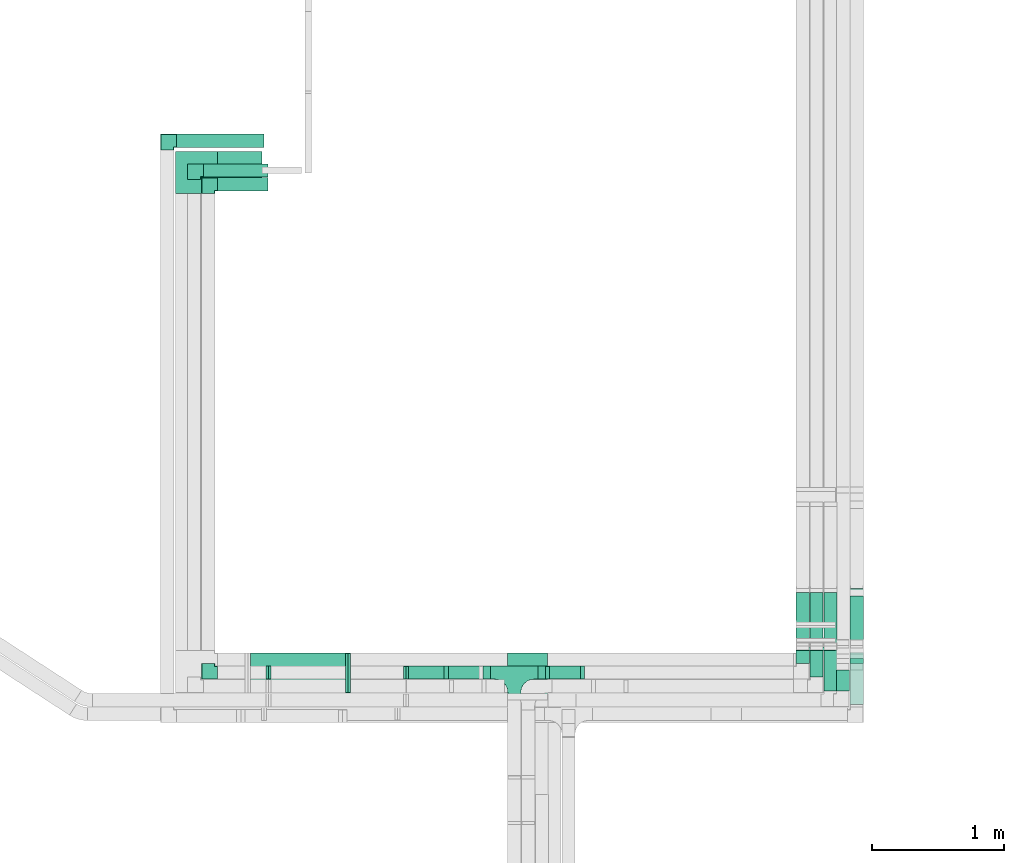
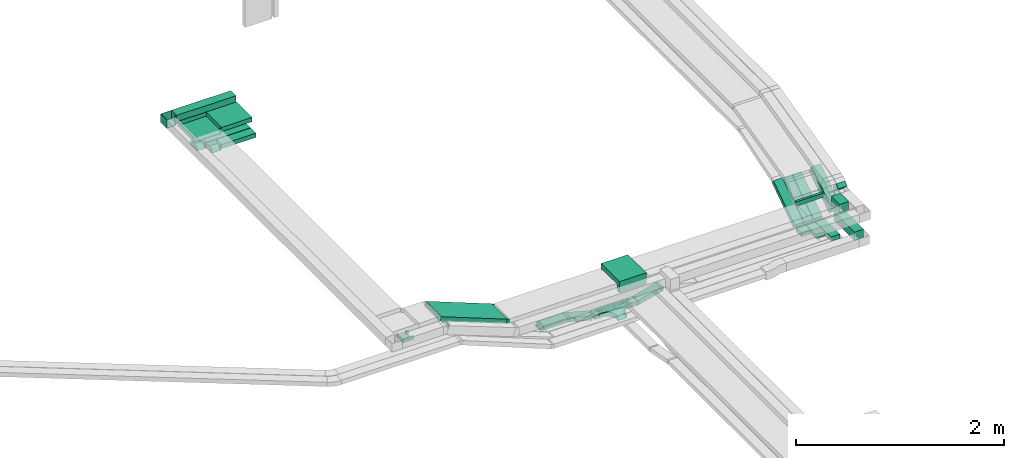
# One storey, part 6 of 14: 21 flow segments, 13 flow fittings.
"""IFC2X3 building model written with IfcOpenShell, lengths in millimetres."""

from ifc_helpers import new_model, entity, si_unit, converted_unit, derived_unit, direction, frame, frame_2d, origin, origin_2d_with_axis, place, context, subcontext, project, spatial, polyline, circle_curve, parameter, trimmed, segment, composite_curve, rectangle, outline, extrude, faceted_brep, source, transform, mapped, material, material_list, type_object, type_shapes, element, save


model = new_model("IFC2X3")

# Units and contexts
model_context = context("Model", 3, precision=0.01, world=origin(), true_north=direction((6.12303176911189e-17, 1.0)))
body_context = subcontext(model_context, "Body", "Model", "MODEL_VIEW")
ifc_project = project(units=[si_unit("LENGTHUNIT", "METRE", prefix="MILLI"), si_unit("AREAUNIT", "SQUARE_METRE"), si_unit("VOLUMEUNIT", "CUBIC_METRE"), converted_unit("PLANEANGLEUNIT", "DEGREE", entity("IfcRatioMeasure", 0.0174532925199433), si_unit("PLANEANGLEUNIT", "RADIAN"), dimensions=[0, 0, 0, 0, 0, 0, 0]), si_unit("MASSUNIT", "GRAM", prefix="KILO"), derived_unit("MASSDENSITYUNIT", [(si_unit("MASSUNIT", "GRAM", prefix="KILO"), 1), (si_unit("LENGTHUNIT", "METRE"), -3)]), derived_unit("MOMENTOFINERTIAUNIT", [(si_unit("LENGTHUNIT", "METRE"), 4)]), si_unit("TIMEUNIT", "SECOND"), si_unit("FREQUENCYUNIT", "HERTZ"), si_unit("THERMODYNAMICTEMPERATUREUNIT", "DEGREE_CELSIUS"), derived_unit("THERMALTRANSMITTANCEUNIT", [(si_unit("MASSUNIT", "GRAM", prefix="KILO"), 1), (si_unit("THERMODYNAMICTEMPERATUREUNIT", "KELVIN"), -1), (si_unit("TIMEUNIT", "SECOND"), -3)]), derived_unit("VOLUMETRICFLOWRATEUNIT", [(si_unit("LENGTHUNIT", "METRE"), 3), (si_unit("TIMEUNIT", "SECOND"), -1)]), derived_unit("MASSFLOWRATEUNIT", [(si_unit("MASSUNIT", "GRAM", prefix="KILO"), 1), (si_unit("TIMEUNIT", "SECOND"), -1)]), derived_unit("ROTATIONALFREQUENCYUNIT", [(si_unit("TIMEUNIT", "SECOND"), -1)]), si_unit("ELECTRICCURRENTUNIT", "AMPERE"), si_unit("ELECTRICVOLTAGEUNIT", "VOLT"), si_unit("POWERUNIT", "WATT"), si_unit("FORCEUNIT", "NEWTON", prefix="KILO"), si_unit("ILLUMINANCEUNIT", "LUX"), si_unit("LUMINOUSFLUXUNIT", "LUMEN"), si_unit("LUMINOUSINTENSITYUNIT", "CANDELA"), derived_unit("USERDEFINED", [(si_unit("MASSUNIT", "GRAM", prefix="KILO"), -1), (si_unit("LENGTHUNIT", "METRE"), -2), (si_unit("TIMEUNIT", "SECOND"), 3), (si_unit("LUMINOUSFLUXUNIT", "LUMEN"), 1)]), derived_unit("LINEARVELOCITYUNIT", [(si_unit("LENGTHUNIT", "METRE"), 1), (si_unit("TIMEUNIT", "SECOND"), -1)]), si_unit("PRESSUREUNIT", "PASCAL"), derived_unit("USERDEFINED", [(si_unit("LENGTHUNIT", "METRE"), -2), (si_unit("MASSUNIT", "GRAM", prefix="KILO"), 1), (si_unit("TIMEUNIT", "SECOND"), -2)]), derived_unit("LINEARFORCEUNIT", [(si_unit("MASSUNIT", "GRAM", prefix="KILO"), 1), (si_unit("LENGTHUNIT", "METRE"), 1), (si_unit("TIMEUNIT", "SECOND"), -2), (si_unit("LENGTHUNIT", "METRE"), -1)]), derived_unit("PLANARFORCEUNIT", [(si_unit("MASSUNIT", "GRAM", prefix="KILO"), 1), (si_unit("LENGTHUNIT", "METRE"), 1), (si_unit("TIMEUNIT", "SECOND"), -2), (si_unit("LENGTHUNIT", "METRE"), -2)])], contexts=[model_context])

# Site, building, storey
site_placement = place(None, origin())
site = spatial("IfcSite", under=ifc_project, at=site_placement, CompositionType="ELEMENT")
building_placement = place(site_placement, origin())
building = spatial("IfcBuilding", under=site, at=building_placement, CompositionType="ELEMENT")
storey_placement = place(building_placement, frame((0.0, 0.0, 19800.0)))
storey = spatial("IfcBuildingStorey", under=building, at=storey_placement, Name="06", CompositionType="ELEMENT", Elevation=19800.0)

# Flow segments
cable_carrier_segment_type = type_object("IfcCableCarrierSegmentType", PredefinedType="CABLETRAYSEGMENT")
flow_segment_1_placement = place(storey_placement, frame((17256.59, 10152.84, 2600.0)))
element("IfcFlowSegment", 1, at=flow_segment_1_placement, inside=storey, type_object=cable_carrier_segment_type, context=body_context, shape_type="SweptSolid", body=[
    extrude(rectangle(XDim=269.725224847366, YDim=99.9999999999989, at=origin_2d_with_axis()), frame((134.86, 50.0, 0.0)), (0.0, 0.0, 1.0), 49.9999999999973),
])
flow_segment_2_placement = place(storey_placement, frame((20600.22, 9960.23, 2600.0)))
element("IfcFlowSegment", 2, at=flow_segment_2_placement, inside=storey, type_object=cable_carrier_segment_type, context=body_context, shape_type="SweptSolid", body=[
    extrude(rectangle(XDim=396.146721820888, YDim=100.000000000003, at=origin_2d_with_axis()), frame((50.0, 198.07, 0.0), z_axis=(0.0, 0.0, 1.0), x_axis=(0.0, 1.0, 0.0)), (0.0, 0.0, 1.0), 99.9999999999989),
])
flow_segment_3_placement = place(storey_placement, frame((20600.22, 10396.27, 2629.3)))
element("IfcFlowSegment", 3, at=flow_segment_3_placement, inside=storey, type_object=cable_carrier_segment_type, context=body_context, shape_type="SweptSolid", body=[
    extrude(rectangle(XDim=100.000000000001, YDim=467.368346274404, at=frame_2d((0.0, 0.0), x_axis=(0.0, 1.0))), frame((0.0, 221.69, 172.13), z_axis=(1.0, 0.0, 0.0), x_axis=(0.0, 0.829037572555048, 0.559192903470738)), (0.0, 0.0, 1.0), 100.000000000003),
])
flow_segment_4_placement = place(storey_placement, frame((20400.22, 10064.24, 2600.0)))
element("IfcFlowSegment", 4, at=flow_segment_4_placement, inside=storey, type_object=cable_carrier_segment_type, context=body_context, shape_type="SweptSolid", body=[
    extrude(rectangle(XDim=311.24039895918, YDim=100.000000000003, at=origin_2d_with_axis()), frame((50.0, 155.62, 0.0), z_axis=(0.0, 0.0, 1.0), x_axis=(0.0, -1.0, 0.0)), (0.0, 0.0, 1.0), 50.0000000000016),
])
flow_segment_5_placement = place(storey_placement, frame((20400.22, 10401.4, 2616.47)))
element("IfcFlowSegment", 5, at=flow_segment_5_placement, inside=storey, type_object=cable_carrier_segment_type, context=body_context, shape_type="SweptSolid", body=[
    extrude(rectangle(XDim=49.9999999999964, YDim=493.947448455053, at=frame_2d((0.0, 0.0), x_axis=(0.0, 1.0))), frame((0.0, 218.73, 158.83), z_axis=(1.0, 0.0, 0.0), x_axis=(0.0, 0.829037572555015, 0.559192903470787)), (0.0, 0.0, 1.0), 100.000000000003),
])
flow_segment_6_placement = place(storey_placement, frame((20295.22, 10401.4, 2616.47)))
element("IfcFlowSegment", 6, at=flow_segment_6_placement, inside=storey, type_object=cable_carrier_segment_type, context=body_context, shape_type="SweptSolid", body=[
    extrude(rectangle(XDim=49.9999999999977, YDim=493.947448455056, at=frame_2d((0.0, 0.0), x_axis=(0.0, 1.0))), frame((0.0, 218.73, 158.83), z_axis=(1.0, 0.0, 0.0), x_axis=(0.0, 0.829037572555018, 0.559192903470783)), (0.0, 0.0, 1.0), 100.000000000003),
])
flow_segment_7_placement = place(storey_placement, frame((20190.22, 10401.4, 2616.47)))
element("IfcFlowSegment", 7, at=flow_segment_7_placement, inside=storey, type_object=cable_carrier_segment_type, context=body_context, shape_type="SweptSolid", body=[
    extrude(rectangle(XDim=49.9999999999964, YDim=493.947448455053, at=frame_2d((0.0, 0.0), x_axis=(0.0, 1.0))), frame((0.0, 218.73, 158.83), z_axis=(1.0, 0.0, 0.0), x_axis=(0.0, 0.829037572555015, 0.559192903470787)), (0.0, 0.0, 1.0), 100.000000000003),
])
flow_segment_8_placement = place(storey_placement, frame((20295.22, 10169.82, 2600.0)))
element("IfcFlowSegment", 8, at=flow_segment_8_placement, inside=storey, type_object=cable_carrier_segment_type, context=body_context, shape_type="SweptSolid", body=[
    extrude(rectangle(XDim=205.655049876662, YDim=100.000000000003, at=origin_2d_with_axis()), frame((50.0, 102.83, 0.0), z_axis=(0.0, 0.0, 1.0), x_axis=(0.0, -1.0, 0.0)), (0.0, 0.0, 1.0), 49.999999999993),
])
flow_segment_9_placement = place(storey_placement, frame((20190.22, 10272.84, 2600.0)))
element("IfcFlowSegment", 9, at=flow_segment_9_placement, inside=storey, type_object=cable_carrier_segment_type, context=body_context, shape_type="SweptSolid", body=[
    extrude(rectangle(XDim=102.633638913558, YDim=100.000000000003, at=origin_2d_with_axis()), frame((50.0, 51.32, 0.0), z_axis=(0.0, 0.0, 1.0), x_axis=(0.0, 1.0, 0.0)), (0.0, 0.0, 1.0), 49.9999999999973),
])
flow_segment_10_placement = place(storey_placement, frame((20600.22, 10271.78, 2948.93)))
element("IfcFlowSegment", 10, at=flow_segment_10_placement, inside=storey, type_object=cable_carrier_segment_type, context=body_context, shape_type="SweptSolid", body=[
    extrude(rectangle(XDim=53.3220562203544, YDim=99.999999999999, at=origin_2d_with_axis()), frame((0.0, 54.21, 54.21), z_axis=(1.0, 0.0, 0.0), x_axis=(0.0, -0.707106781186487, -0.707106781186608)), (0.0, 0.0, 1.0), 100.000000000003),
])
flow_segment_11_placement = place(storey_placement, frame((20495.22, 10064.24, 2900.0)))
element("IfcFlowSegment", 11, at=flow_segment_11_placement, inside=storey, type_object=cable_carrier_segment_type, context=body_context, shape_type="SweptSolid", body=[
    extrude(rectangle(XDim=160.114335996502, YDim=100.000000000003, at=origin_2d_with_axis()), frame((50.0, 80.06, 0.0), z_axis=(0.0, 0.0, 1.0), x_axis=(0.0, 1.0, 0.0)), (0.0, 0.0, 1.0), 100.000000000003),
])
flow_segment_12_placement = place(storey_placement, frame((20190.22, 10370.13, 2900.0)))
element("IfcFlowSegment", 12, at=flow_segment_12_placement, inside=storey, type_object=cable_carrier_segment_type, context=body_context, shape_type="SweptSolid", body=[
    extrude(rectangle(XDim=28.3940759827228, YDim=300.000000000001, at=origin_2d_with_axis()), frame((150.0, 14.2, 0.0), z_axis=(0.0, 0.0, 1.0), x_axis=(0.0, -1.0, 0.0)), (0.0, 0.0, 1.0), 49.999999999993),
])
flow_segment_13_placement = place(storey_placement, frame((18310.63, 10152.84, 2531.55)))
element("IfcFlowSegment", 13, at=flow_segment_13_placement, inside=storey, type_object=cable_carrier_segment_type, context=body_context, shape_type="SweptSolid", body=[
    extrude(rectangle(XDim=49.9999999999963, YDim=99.9999999999989, at=origin_2d_with_axis()), frame((6.47, 50.0, 24.15), z_axis=(0.965925826289085, 0.0, 0.258819045102459), x_axis=(-0.258819045102459, 0.0, 0.965925826289085)), (0.0, 0.0, 1.0), 255.518225265326),
])
flow_segment_14_placement = place(storey_placement, frame((18237.14, 10152.84, 2527.53)))
element("IfcFlowSegment", 14, at=flow_segment_14_placement, inside=storey, type_object=cable_carrier_segment_type, context=body_context, shape_type="SweptSolid", body=[
    extrude(rectangle(XDim=55.8887887634152, YDim=99.9999999999989, at=origin_2d_with_axis()), frame((27.94, 50.0, 0.0), z_axis=(0.0, 0.0, 1.0), x_axis=(-1.0, 0.0, 0.0)), (0.0, 0.0, 1.0), 49.9999999999973),
])
flow_segment_15_placement = place(storey_placement, frame((17543.91, 10152.84, 2531.55)))
element("IfcFlowSegment", 15, at=flow_segment_15_placement, inside=storey, type_object=cable_carrier_segment_type, context=body_context, shape_type="SweptSolid", body=[
    extrude(rectangle(XDim=49.9999999999963, YDim=99.9999999999989, at=frame_2d((0.0, 0.0), x_axis=(0.0, 1.0))), frame((6.47, 50.0, 90.28), z_axis=(0.965925826289085, 0.0, -0.258819045102459), x_axis=(0.0, 1.0, 0.0)), (0.0, 0.0, 1.0), 255.518225265326),
])
flow_segment_16_placement = place(storey_placement, frame((17821.26, 10152.84, 2527.53)))
element("IfcFlowSegment", 16, at=flow_segment_16_placement, inside=storey, type_object=cable_carrier_segment_type, context=body_context, shape_type="SweptSolid", body=[
    extrude(rectangle(XDim=55.8887887635105, YDim=99.9999999999989, at=origin_2d_with_axis()), frame((27.94, 50.0, 0.0)), (0.0, 0.0, 1.0), 49.9999999999973),
])
flow_segment_17_placement = place(storey_placement, frame((16040.11, 10050.13, 2907.31)))
element("IfcFlowSegment", 17, at=flow_segment_17_placement, inside=storey, type_object=cable_carrier_segment_type, context=body_context, shape_type="SweptSolid", body=[
    extrude(rectangle(XDim=49.9999999999997, YDim=300.000000000001, at=frame_2d((0.0, 0.0), x_axis=(0.0, 1.0))), frame((9.1, 150.0, 312.1), z_axis=(0.931412677772554, 0.0, -0.36396486600297), x_axis=(0.0, 1.0, 0.0)), (0.0, 0.0, 1.0), 793.526444095363),
])
flow_segment_18_placement = place(storey_placement, frame((15810.0, 13850.13, 3200.0)))
element("IfcFlowSegment", 18, at=flow_segment_18_placement, inside=storey, type_object=cable_carrier_segment_type, context=body_context, shape_type="SweptSolid", body=[
    extrude(rectangle(XDim=337.305497573283, YDim=300.000000000001, at=origin_2d_with_axis()), frame((168.65, 150.0, 0.0)), (0.0, 0.0, 1.0), 49.9999999999973),
])
flow_segment_19_placement = place(storey_placement, frame((15498.62, 14180.23, 3200.0)))
element("IfcFlowSegment", 19, at=flow_segment_19_placement, inside=storey, type_object=cable_carrier_segment_type, context=body_context, shape_type="SweptSolid", body=[
    extrude(rectangle(XDim=661.375838147948, YDim=99.9999999999989, at=origin_2d_with_axis()), frame((330.69, 50.0, 0.0)), (0.0, 0.0, 1.0), 100.000000000003),
])
flow_segment_20_placement = place(storey_placement, frame((15810.0, 13850.13, 3000.0)))
element("IfcFlowSegment", 20, at=flow_segment_20_placement, inside=storey, type_object=cable_carrier_segment_type, context=body_context, shape_type="SweptSolid", body=[
    extrude(rectangle(XDim=381.506330110017, YDim=99.9999999999989, at=origin_2d_with_axis()), frame((190.75, 50.0, 0.0)), (0.0, 0.0, 1.0), 49.9999999999973),
])
flow_segment_21_placement = place(storey_placement, frame((15701.77, 13954.94, 3000.0)))
element("IfcFlowSegment", 21, at=flow_segment_21_placement, inside=storey, type_object=cable_carrier_segment_type, context=body_context, shape_type="SweptSolid", body=[
    extrude(rectangle(XDim=489.733815594426, YDim=99.9999999999989, at=origin_2d_with_axis()), frame((244.87, 50.0, 0.0)), (0.0, 0.0, 1.0), 49.9999999999973),
])

# Flow fittings
ifc_material = material()
cable_carrier_fitting_type_1 = type_object("IfcCableCarrierFittingType", PredefinedType="NOTDEFINED", material=ifc_material)
shared_shape_1 = source(origin(), body_context, "Body", "Brep", [
    faceted_brep([(-53.41, -124.12, 25.0), (-50.0, -150.0, 25.0), (-50.0, -180.0, 25.0), (-49.2, -180.0, 25.0), (-49.2, -150.0, 25.0), (-52.63, -123.91, 25.0), (-62.7, -99.6, 25.0), (-78.72, -78.72, 25.0), (-99.6, -62.7, 25.0), (-123.91, -52.63, 25.0), (-150.0, -49.2, 25.0), (-180.0, -49.2, 25.0), (-180.0, -50.0, 25.0), (-150.0, -50.0, 25.0), (-124.12, -53.41, 25.0), (-100.0, -63.4, 25.0), (-79.29, -79.29, 25.0), (-63.4, -100.0, 25.0), (180.0, -50.0, 25.0), (180.0, -49.2, 25.0), (150.0, -49.2, 25.0), (123.91, -52.63, 25.0), (99.6, -62.7, 25.0), (78.72, -78.72, 25.0), (62.7, -99.6, 25.0), (52.63, -123.91, 25.0), (49.2, -150.0, 25.0), (49.2, -180.0, 25.0), (50.0, -180.0, 25.0), (50.0, -150.0, 25.0), (53.41, -124.12, 25.0), (63.4, -100.0, 25.0), (79.29, -79.29, 25.0), (100.0, -63.4, 25.0), (124.12, -53.41, 25.0), (150.0, -50.0, 25.0), (180.0, 49.2, 25.0), (180.0, 50.0, 25.0), (-180.0, 50.0, 25.0), (-180.0, 49.2, 25.0), (-180.0, -50.0, -25.0), (-180.0, 50.0, -25.0), (180.0, 50.0, -25.0), (180.0, -50.0, -25.0), (150.0, -50.0, -25.0), (124.12, -53.41, -25.0), (100.0, -63.4, -25.0), (79.29, -79.29, -25.0), (63.4, -100.0, -25.0), (53.41, -124.12, -25.0), (50.0, -150.0, -25.0), (50.0, -180.0, -25.0), (-50.0, -180.0, -25.0), (-50.0, -150.0, -25.0), (-53.41, -124.12, -25.0), (-63.4, -100.0, -25.0), (-79.29, -79.29, -25.0), (-100.0, -63.4, -25.0), (-124.12, -53.41, -25.0), (-150.0, -50.0, -25.0), (-50.0, -150.0, -24.2), (49.2, -180.0, -24.2), (-49.2, -180.0, -24.2), (-49.2, -150.0, -24.2), (-150.0, -49.2, -24.2), (-180.0, -49.2, -24.2), (180.0, -49.2, -24.2), (150.0, -49.2, -24.2), (-180.0, 49.2, -24.2), (-150.0, -50.0, -24.2), (150.0, -50.0, -24.2), (180.0, 49.2, -24.2), (49.2, -150.0, -24.2), (50.0, -150.0, -24.2), (-123.91, -52.63, -24.2), (-99.6, -62.7, -24.2), (-78.72, -78.72, -24.2), (-62.7, -99.6, -24.2), (-52.63, -123.91, -24.2), (52.63, -123.91, -24.2), (62.7, -99.6, -24.2), (78.72, -78.72, -24.2), (99.6, -62.7, -24.2), (123.91, -52.63, -24.2)], [[[0, 1, 2, 3, 4, 5, 6, 7, 8, 9, 10, 11, 12, 13, 14, 15, 16, 17]], [[18, 19, 20, 21, 22, 23, 24, 25, 26, 27, 28, 29, 30, 31, 32, 33, 34, 35]], [[36, 37, 38, 39]], [[40, 41, 42, 43, 44, 45, 46, 47, 48, 49, 50, 51, 52, 53, 54, 55, 56, 57, 58, 59]], [[2, 1, 60, 53, 52]], [[3, 2, 52, 51, 28, 27, 61, 62]], [[4, 3, 62, 63]], [[11, 10, 64, 65]], [[20, 19, 66, 67]], [[39, 38, 41, 40, 12, 11, 65, 68]], [[13, 12, 40, 59, 69]], [[18, 35, 70, 44, 43]], [[19, 18, 43, 42, 37, 36, 71, 66]], [[27, 26, 72, 61]], [[29, 28, 51, 50, 73]], [[38, 37, 42, 41]], [[36, 39, 68, 71]], [[68, 65, 64, 74, 75, 76, 77, 78, 63, 62, 61, 72, 79, 80, 81, 82, 83, 67, 66, 71]], [[14, 13, 69, 59, 58]], [[58, 57, 15, 14]], [[15, 57, 56, 16]], [[0, 17, 55, 54]], [[0, 54, 53, 60, 1]], [[55, 17, 16, 56]], [[5, 4, 63, 78]], [[6, 5, 78, 77]], [[7, 6, 77, 76]], [[8, 7, 76, 75]], [[9, 8, 75, 74]], [[10, 9, 74, 64]], [[21, 20, 67, 83]], [[22, 21, 83, 82]], [[23, 22, 82, 81]], [[81, 80, 24, 23]], [[24, 80, 79, 25]], [[79, 72, 26, 25]], [[30, 29, 73, 50, 49]], [[31, 30, 49, 48]], [[31, 48, 47, 32]], [[33, 32, 47, 46]], [[45, 34, 33, 46]], [[34, 45, 44, 70, 35]]]),
])
type_shapes(cable_carrier_fitting_type_1, [shared_shape_1])
flow_fitting_1_placement = place(storey_placement, frame((18057.14, 10202.84, 2552.53)))
element("IfcFlowFitting", 22, at=flow_fitting_1_placement, inside=storey, type_object=cable_carrier_fitting_type_1, material=ifc_material, Name="470_DKC_S5_T", context=body_context, shape_type="MappedRepresentation", body=[
    mapped(shared_shape_1, transform((0.0, 0.0, 0.0), scale=1.0)),
])
cable_carrier_fitting_type_2 = type_object("IfcCableCarrierFittingType", Name="ADSK_ _ :", PredefinedType="NOTDEFINED", material=ifc_material)
shared_shape_2 = source(origin(), body_context, "Body", "Brep", [
    faceted_brep([(-70.0, 50.0, -25.0), (-70.0, -50.0, -25.0), (-70.0, -50.0, 25.0), (-70.0, -47.46, 25.0), (-70.0, -47.46, -22.46), (-70.0, 47.46, -22.46), (-70.0, 47.46, 25.0), (-70.0, 50.0, 25.0), (-50.0, 50.0, -25.0), (-50.0, 70.0, -25.0), (50.0, 70.0, -25.0), (50.0, -50.0, -25.0), (50.0, -50.0, 25.0), (50.0, 70.0, 25.0), (47.46, 70.0, 25.0), (47.46, -47.46, 25.0), (47.46, -47.46, -22.46), (47.46, 70.0, -22.46), (-47.46, 70.0, -22.46), (-47.46, 47.46, -22.46), (-47.46, 47.46, 25.0), (-47.46, 70.0, 25.0), (-50.0, 70.0, 25.0), (-50.0, 50.0, 25.0)], [[[0, 1, 2, 3, 4, 5, 6, 7]], [[1, 0, 8, 9, 10, 11]], [[2, 1, 11, 12]], [[3, 2, 12, 13, 14, 15]], [[4, 3, 15, 16]], [[5, 4, 16, 17, 18, 19]], [[6, 5, 19, 20]], [[7, 6, 20, 21, 22, 23]], [[0, 7, 23, 8]], [[9, 22, 21, 18, 17, 14, 13, 10]], [[12, 11, 10, 13]], [[16, 15, 14, 17]], [[20, 19, 18, 21]], [[8, 23, 22, 9]]]),
])
type_shapes(cable_carrier_fitting_type_2, [shared_shape_2])
for number, where, z_axis, x_axis, name in (
    (23, (15740.0, 10202.84, 3025.0), (0.0, 0.0, 1.0), (0.0, -1.0, 0.0), "ADSK_ _ :"),
    (24, (15740.0, 13900.13, 3025.0), (0.0, 0.0, 1.0), (-1.0, 0.0, 0.0), "ADSK_ _ :"),
    (25, (15631.77, 14004.94, 3025.0), (0.0, 0.0, 1.0), (-1.0, 0.0, 0.0), "ADSK_ _ :"),
):
    element("IfcFlowFitting", number, at=place(storey_placement, frame(where, z_axis=z_axis, x_axis=x_axis)), inside=storey, type_object=cable_carrier_fitting_type_2, material=ifc_material, Name=name, ObjectType="ADSK_ _ :", context=body_context, shape_type="MappedRepresentation", body=[
        mapped(shared_shape_2, transform((0.0, 0.0, 0.0), scale=1.0)),
    ])
cable_carrier_fitting_type_3 = type_object("IfcCableCarrierFittingType", Name="ADSK_ _ :", PredefinedType="NOTDEFINED", material=ifc_material)
shared_shape_3 = source(origin(), body_context, "Body", "Brep", [
    faceted_brep([(-170.0, 150.0, -25.0), (-170.0, -150.0, -25.0), (-170.0, -150.0, 25.0), (-170.0, -147.46, 25.0), (-170.0, -147.46, -22.46), (-170.0, 147.46, -22.46), (-170.0, 147.46, 25.0), (-170.0, 150.0, 25.0), (-150.0, 150.0, -25.0), (-150.0, 170.0, -25.0), (150.0, 170.0, -25.0), (150.0, -150.0, -25.0), (150.0, -150.0, 25.0), (150.0, 170.0, 25.0), (147.46, 170.0, 25.0), (147.46, -147.46, 25.0), (147.46, -147.46, -22.46), (147.46, 170.0, -22.46), (-147.46, 170.0, -22.46), (-147.46, 147.46, -22.46), (-147.46, 147.46, 25.0), (-147.46, 170.0, 25.0), (-150.0, 170.0, 25.0), (-150.0, 150.0, 25.0)], [[[0, 1, 2, 3, 4, 5, 6, 7]], [[1, 0, 8, 9, 10, 11]], [[2, 1, 11, 12]], [[3, 2, 12, 13, 14, 15]], [[4, 3, 15, 16]], [[5, 4, 16, 17, 18, 19]], [[6, 5, 19, 20]], [[7, 6, 20, 21, 22, 23]], [[0, 7, 23, 8]], [[9, 22, 21, 18, 17, 14, 13, 10]], [[12, 11, 10, 13]], [[16, 15, 14, 17]], [[20, 19, 18, 21]], [[8, 23, 22, 9]]]),
])
type_shapes(cable_carrier_fitting_type_3, [shared_shape_3])
flow_fitting_2_placement = place(storey_placement, frame((15640.0, 14000.13, 3225.0), z_axis=(0.0, 0.0, 1.0), x_axis=(-1.0, 0.0, 0.0)))
element("IfcFlowFitting", 26, at=flow_fitting_2_placement, inside=storey, type_object=cable_carrier_fitting_type_3, material=ifc_material, Name="ADSK_ _ :", ObjectType="ADSK_ _ :", context=body_context, shape_type="MappedRepresentation", body=[
    mapped(shared_shape_3, transform((0.0, 0.0, 0.0), scale=1.0)),
])
cable_carrier_fitting_type_4 = type_object("IfcCableCarrierFittingType", Name="ADSK_ _ :", PredefinedType="NOTDEFINED", material=ifc_material)
shared_shape_4 = source(origin(), body_context, "Body", "Brep", [
    faceted_brep([(-70.0, 50.0, -50.0), (-70.0, -50.0, -50.0), (-70.0, -50.0, 50.0), (-70.0, -47.46, 50.0), (-70.0, -47.46, -47.46), (-70.0, 47.46, -47.46), (-70.0, 47.46, 50.0), (-70.0, 50.0, 50.0), (-50.0, 50.0, -50.0), (-50.0, 70.0, -50.0), (50.0, 70.0, -50.0), (50.0, -50.0, -50.0), (50.0, -50.0, 50.0), (50.0, 70.0, 50.0), (47.46, 70.0, 50.0), (47.46, -47.46, 50.0), (47.46, -47.46, -47.46), (47.46, 70.0, -47.46), (-47.46, 70.0, -47.46), (-47.46, 47.46, -47.46), (-47.46, 47.46, 50.0), (-47.46, 70.0, 50.0), (-50.0, 70.0, 50.0), (-50.0, 50.0, 50.0)], [[[0, 1, 2, 3, 4, 5, 6, 7]], [[1, 0, 8, 9, 10, 11]], [[2, 1, 11, 12]], [[3, 2, 12, 13, 14, 15]], [[4, 3, 15, 16]], [[5, 4, 16, 17, 18, 19]], [[6, 5, 19, 20]], [[7, 6, 20, 21, 22, 23]], [[0, 7, 23, 8]], [[9, 22, 21, 18, 17, 14, 13, 10]], [[12, 11, 10, 13]], [[16, 15, 14, 17]], [[20, 19, 18, 21]], [[8, 23, 22, 9]]]),
])
type_shapes(cable_carrier_fitting_type_4, [shared_shape_4])
flow_fitting_3_placement = place(storey_placement, frame((15428.62, 14230.23, 3250.0), z_axis=(0.0, 0.0, 1.0), x_axis=(-1.0, 0.0, 0.0)))
element("IfcFlowFitting", 27, at=flow_fitting_3_placement, inside=storey, type_object=cable_carrier_fitting_type_4, material=ifc_material, Name="ADSK_ _ :", ObjectType="ADSK_ _ :", context=body_context, shape_type="MappedRepresentation", body=[
    mapped(shared_shape_4, transform((0.0, 0.0, 0.0), scale=1.0)),
])
cable_carrier_fitting_type_5 = type_object("IfcCableCarrierFittingType", PredefinedType="NOTDEFINED", material=ifc_material)
shared_shape_5 = source(origin(), body_context, "Body", "Brep", [
    faceted_brep([(-15.12, -25.0, 50.0), (-15.12, 25.0, 50.0), (-15.12, 25.0, 47.46), (-15.12, -22.46, 47.46), (-15.12, -22.46, -47.46), (-15.12, 25.0, -47.46), (-15.12, 25.0, -50.0), (-15.12, -25.0, -50.0), (23.03, -17.98, 50.0), (23.03, -17.98, -50.0), (5.23, 28.75, -50.0), (5.23, 28.75, -47.46), (22.13, -15.61, -47.46), (22.13, -15.61, 47.46), (5.23, 28.75, 47.46), (5.23, 28.75, 50.0), (4.6, -25.0, 50.0), (-4.6, 25.0, 50.0), (-4.6, 25.0, 47.46), (4.13, -22.46, 47.46), (4.13, -22.46, -47.46), (-4.6, 25.0, -47.46), (-4.6, 25.0, -50.0), (4.6, -25.0, -50.0)], [[[0, 1, 2, 3, 4, 5, 6, 7]], [[8, 9, 10, 11, 12, 13, 14, 15]], [[1, 0, 16, 8, 15, 17]], [[2, 1, 17, 18]], [[3, 2, 18, 14, 13, 19]], [[4, 3, 19, 20]], [[5, 4, 20, 12, 11, 21]], [[6, 5, 21, 22]], [[7, 6, 22, 10, 9, 23]], [[0, 7, 23, 16]], [[18, 17, 15, 14]], [[20, 19, 13, 12]], [[22, 21, 11, 10]], [[16, 23, 9, 8]]]),
])
type_shapes(cable_carrier_fitting_type_5, [shared_shape_5])
for number, where, z_axis, x_axis in (
    (28, (17241.47, 10202.84, 2625.0), (0.0, -1.0, 0.0), (0.934483298097407, 0.0, -0.356006974056678)),
    (29, (16191.51, 10202.84, 3025.0), (0.0, -1.0, 0.0), (-0.934483298097407, 0.0, 0.356006974056678)),
):
    element("IfcFlowFitting", number, at=place(storey_placement, frame(where, z_axis=z_axis, x_axis=x_axis)), inside=storey, type_object=cable_carrier_fitting_type_5, material=ifc_material, context=body_context, shape_type="MappedRepresentation", body=[
        mapped(shared_shape_5, transform((0.0, 0.0, 0.0), scale=1.0)),
    ])
cable_carrier_fitting_type_6 = type_object("IfcCableCarrierFittingType", PredefinedType="NOTDEFINED", material=ifc_material)
shared_shape_6 = source(origin(), body_context, "Body", "Brep", [
    faceted_brep([(-12.24, -25.0, 50.0), (-12.24, 25.0, 50.0), (-12.24, 25.0, 47.46), (-12.24, -22.46, 47.46), (-12.24, -22.46, -47.46), (-12.24, 25.0, -47.46), (-12.24, 25.0, -50.0), (-12.24, -25.0, -50.0), (18.29, -20.98, 50.0), (18.29, -20.98, -50.0), (5.35, 27.32, -50.0), (5.35, 27.32, -47.46), (17.64, -18.53, -47.46), (17.64, -18.53, 47.46), (5.35, 27.32, 47.46), (5.35, 27.32, 50.0), (3.29, -25.0, 50.0), (-3.29, 25.0, 50.0), (-3.29, 25.0, 47.46), (2.96, -22.46, 47.46), (2.96, -22.46, -47.46), (-3.29, 25.0, -47.46), (-3.29, 25.0, -50.0), (3.29, -25.0, -50.0)], [[[0, 1, 2, 3, 4, 5, 6, 7]], [[8, 9, 10, 11, 12, 13, 14, 15]], [[1, 0, 16, 8, 15, 17]], [[2, 1, 17, 18]], [[3, 2, 18, 14, 13, 19]], [[4, 3, 19, 20]], [[5, 4, 20, 12, 11, 21]], [[6, 5, 21, 22]], [[7, 6, 22, 10, 9, 23]], [[0, 7, 23, 16]], [[18, 17, 15, 14]], [[20, 19, 13, 12]], [[22, 21, 11, 10]], [[16, 23, 9, 8]]]),
])
type_shapes(cable_carrier_fitting_type_6, [shared_shape_6])
for number, where, z_axis, x_axis in (
    (30, (18575.73, 10202.84, 2625.0), (0.0, -1.0, 0.0), (-1.0, 0.0, 0.0)),
    (31, (18305.27, 10202.84, 2552.53), (0.0, 1.0, 0.0), (-0.965925826289095, 0.0, -0.258819045102422)),
    (32, (17538.56, 10202.84, 2625.0), (0.0, -1.0, 0.0), (-0.965925826289095, 0.0, 0.258819045102422)),
):
    element("IfcFlowFitting", number, at=place(storey_placement, frame(where, z_axis=z_axis, x_axis=x_axis)), inside=storey, type_object=cable_carrier_fitting_type_6, material=ifc_material, context=body_context, shape_type="MappedRepresentation", body=[
        mapped(shared_shape_6, transform((0.0, 0.0, 0.0), scale=1.0)),
    ])
cable_carrier_fitting_type_7 = type_object("IfcCableCarrierFittingType", PredefinedType="NOTDEFINED", material=ifc_material)
shared_shape_7 = source(origin(), body_context, "Body", "Brep", [
    faceted_brep([(-15.36, -25.0, 150.0), (-15.36, 25.0, 150.0), (-15.36, 25.0, 147.46), (-15.36, -22.46, 147.46), (-15.36, -22.46, -147.46), (-15.36, 25.0, -147.46), (-15.36, 25.0, -150.0), (-15.36, -25.0, -150.0), (23.41, -17.69, 150.0), (23.41, -17.69, -150.0), (5.21, 28.88, -150.0), (5.21, 28.88, -147.46), (22.49, -15.33, -147.46), (22.49, -15.33, 147.46), (5.21, 28.88, 147.46), (5.21, 28.88, 150.0), (4.71, -25.0, 150.0), (-4.71, 25.0, 150.0), (-4.71, 25.0, 147.46), (4.23, -22.46, 147.46), (4.23, -22.46, -147.46), (-4.71, 25.0, -147.46), (-4.71, 25.0, -150.0), (4.71, -25.0, -150.0)], [[[0, 1, 2, 3, 4, 5, 6, 7]], [[8, 9, 10, 11, 12, 13, 14, 15]], [[1, 0, 16, 8, 15, 17]], [[2, 1, 17, 18]], [[3, 2, 18, 14, 13, 19]], [[4, 3, 19, 20]], [[5, 4, 20, 12, 11, 21]], [[6, 5, 21, 22]], [[7, 6, 22, 10, 9, 23]], [[0, 7, 23, 16]], [[18, 17, 15, 14]], [[20, 19, 13, 12]], [[22, 21, 11, 10]], [[16, 23, 9, 8]]]),
])
type_shapes(cable_carrier_fitting_type_7, [shared_shape_7])
flow_fitting_4_placement = place(storey_placement, frame((16802.62, 10200.13, 2925.0), z_axis=(0.0, -1.0, 0.0), x_axis=(0.931412677772567, 0.0, -0.363964866002938)))
element("IfcFlowFitting", 33, at=flow_fitting_4_placement, inside=storey, type_object=cable_carrier_fitting_type_7, material=ifc_material, context=body_context, shape_type="MappedRepresentation", body=[
    mapped(shared_shape_7, transform((0.0, 0.0, 0.0), scale=1.0)),
])
ifc_material_list = material_list([ifc_material, ifc_material, ifc_material, ifc_material, ifc_material])
cable_carrier_fitting_type_8 = type_object("IfcCableCarrierFittingType", PredefinedType="NOTDEFINED", material=ifc_material_list)
shared_shape_8 = source(origin(), body_context, "Body", "SweptSolid", [
    extrude(outline(composite_curve([segment(polyline([(-61.86, -231.43), (-7.86, -231.43)]), True, "CONTINUOUS"), segment(polyline([(-7.86, -231.43), (-7.86, 68.57)]), True, "CONTINUOUS"), segment(trimmed(circle_curve(frame_2d((-2.86, 68.57), x_axis=(0.0, -1.0)), 5.0), [parameter(180.0)], [parameter(270.0)], True, "PARAMETER"), False, "CONTINUOUS"), segment(polyline([(-2.86, 73.57), (71.14, 73.57)]), True, "CONTINUOUS"), segment(polyline([(71.14, 73.57), (71.14, 123.57)]), True, "CONTINUOUS"), segment(polyline([(71.14, 123.57), (-61.86, 123.57)]), True, "CONTINUOUS"), segment(polyline([(-61.86, 123.57), (-61.86, -231.43)]), True, "CONTINUOUS")], self_intersect=False)), frame((-81.43, -150.0, 17.14), z_axis=(0.0, 1.0, 0.0), x_axis=(0.0, 0.0, -1.0)), (0.0, 0.0, 1.0), 0.799999999999987),
    extrude(rectangle(XDim=0.799999999999852, YDim=300.0, at=origin_2d_with_axis()), frame((149.6, 0.0, -7.5), z_axis=(0.0, 0.0, 1.0), x_axis=(-1.0, 0.0, 0.0)), (0.0, 0.0, 1.0), 86.4999999999327),
    extrude(rectangle(XDim=355.0, YDim=300.0, at=origin_2d_with_axis()), frame((-27.5, 0.0, 78.2), z_axis=(0.0, 0.0, 1.0), x_axis=(-1.0, 0.0, 0.0)), (0.0, 0.0, 1.0), 0.800000000000055),
    extrude(rectangle(XDim=0.79999999999992, YDim=298.4, at=origin_2d_with_axis()), frame((-204.6, 0.0, -54.0), z_axis=(0.0, 0.0, 1.0), x_axis=(-1.0, 0.0, 0.0)), (0.0, 0.0, 1.0), 132.999999999999),
    extrude(outline(composite_curve([segment(polyline([(-61.86, -231.43), (-7.86, -231.43)]), True, "CONTINUOUS"), segment(polyline([(-7.86, -231.43), (-7.86, 68.57)]), True, "CONTINUOUS"), segment(trimmed(circle_curve(frame_2d((-2.86, 68.57), x_axis=(0.0, -1.0)), 5.0), [parameter(180.0)], [parameter(270.0)], True, "PARAMETER"), False, "CONTINUOUS"), segment(polyline([(-2.86, 73.57), (71.14, 73.57)]), True, "CONTINUOUS"), segment(polyline([(71.14, 73.57), (71.14, 123.57)]), True, "CONTINUOUS"), segment(polyline([(71.14, 123.57), (-61.86, 123.57)]), True, "CONTINUOUS"), segment(polyline([(-61.86, 123.57), (-61.86, -231.43)]), True, "CONTINUOUS")], self_intersect=False)), frame((-81.43, 149.2, 17.14), z_axis=(0.0, 1.0, 0.0), x_axis=(0.0, 0.0, -1.0)), (0.0, 0.0, 1.0), 0.799999999999784),
])
type_shapes(cable_carrier_fitting_type_8, [shared_shape_8])
flow_fitting_5_placement = place(storey_placement, frame((18157.14, 10200.13, 2925.0), z_axis=(0.0, 0.0, 1.0), x_axis=(0.0, 1.0, 0.0)))
element("IfcFlowFitting", 34, at=flow_fitting_5_placement, inside=storey, type_object=cable_carrier_fitting_type_8, material=ifc_material_list, Name="470_DKC_S5_vertical T-shaped cover", context=body_context, shape_type="MappedRepresentation", body=[
    mapped(shared_shape_8, transform((0.0, 0.0, 0.0), scale=1.0)),
])

save(model, "model.ifc")
